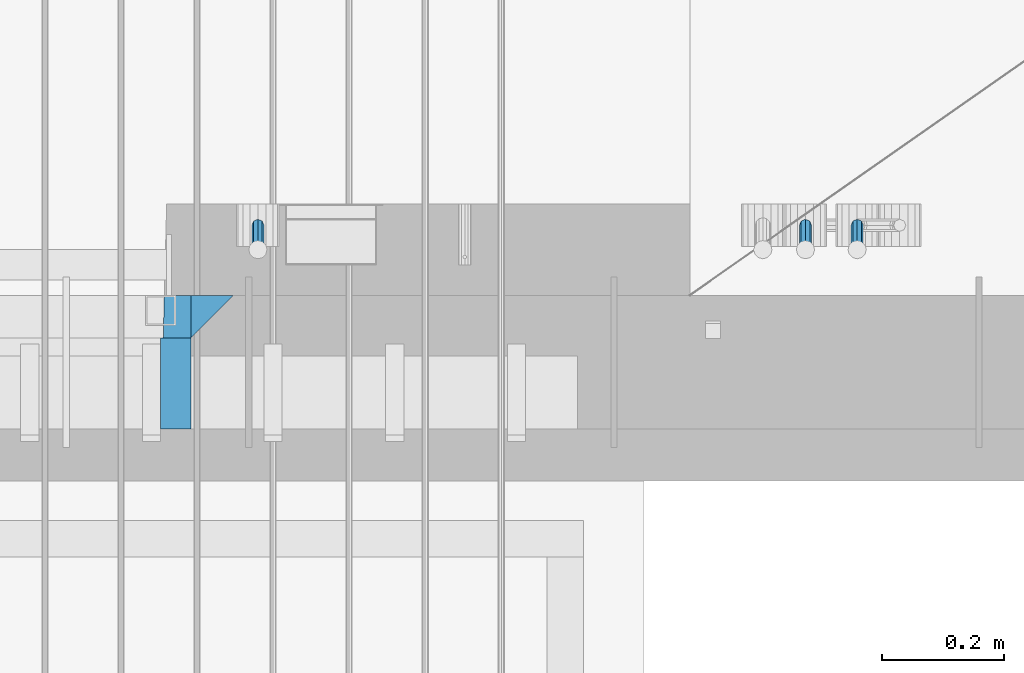
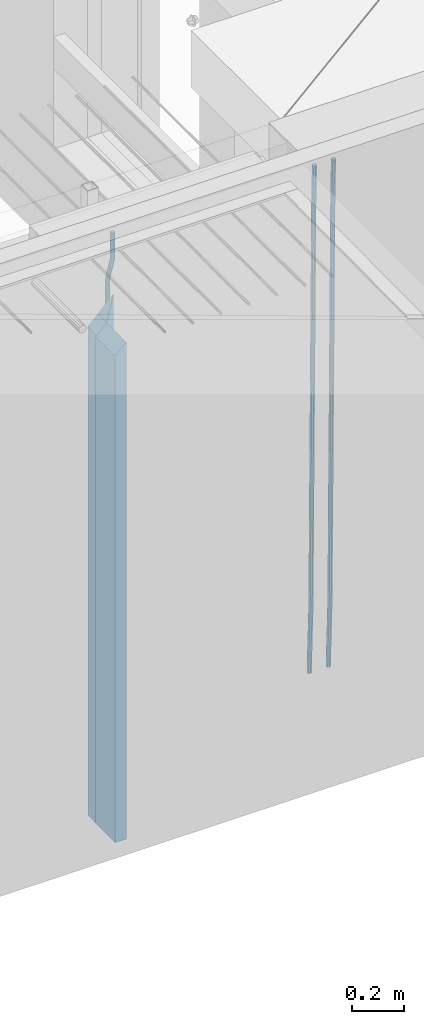
# One storey, part 125 of 341: 6 beams, 1 element without a shape of its own.
"""IFC2X3 building model written with IfcOpenShell, lengths in millimetres."""

from ifc_helpers import new_model, si_unit, frame, origin_with_axes, place, context, subcontext, project, spatial, faceted_brep, material, type_object, element, aggregate, save


model = new_model("IFC2X3")

# Units and contexts
model_context = context("Model", 3, precision=1e-05, world=origin_with_axes())
body_context = subcontext(model_context, "Body", "Model", "MODEL_VIEW")
ifc_project = project(units=[si_unit("LENGTHUNIT", "METRE", prefix="MILLI"), si_unit("AREAUNIT", "SQUARE_METRE"), si_unit("VOLUMEUNIT", "CUBIC_METRE"), si_unit("MASSUNIT", "GRAM", prefix="KILO"), si_unit("TIMEUNIT", "SECOND"), si_unit("PLANEANGLEUNIT", "RADIAN"), si_unit("SOLIDANGLEUNIT", "STERADIAN"), si_unit("THERMODYNAMICTEMPERATUREUNIT", "DEGREE_CELSIUS"), si_unit("LUMINOUSINTENSITYUNIT", "LUMEN")], contexts=[model_context])

# Site, building, storey
site_placement = place(None, origin_with_axes())
site = spatial("IfcSite", under=ifc_project, at=site_placement, CompositionType="ELEMENT")
building_placement = place(site_placement, origin_with_axes())
building = spatial("IfcBuilding", under=site, at=building_placement, CompositionType="ELEMENT")
storey_placement = place(building_placement, origin_with_axes())
storey = spatial("IfcBuildingStorey", under=building, at=storey_placement, Name="5", CompositionType="ELEMENT", Elevation=0.0)

# Assembly, beams
assembly_placement = place(storey_placement, origin_with_axes())
assembly = element("IfcElementAssembly", 1, at=assembly_placement, inside=storey, AssemblyPlace="NOTDEFINED", PredefinedType="REINFORCEMENT_UNIT")
ifc_material_1 = material(Name="CONCRETE/C35/45")
beam_type_1 = type_object("IfcBeamType", PredefinedType="NOTDEFINED")
beam_1_placement = place(assembly_placement, frame((33199.9988923323, 7815.0, 96175.0), z_axis=(-1.0, 3.00000001838171e-08, 0.0), x_axis=(0.0, 0.0, -1.0)))
beam_1 = element("IfcBeam", 2, at=beam_1_placement, type_object=beam_type_1, material=ifc_material_1, Name="SK", context=body_context, shape_type="Brep", body=[
    faceted_brep([(2420.0, -35.0, 35.0), (2420.0, -35.0, -35.0), (2420.0, 35.0, 35.0), (0.0, -35.0, -35.0), (70.0000000000164, 35.0, 35.0), (70.0000000000164, -35.0, 35.0)], [[[0, 1, 2]], [[2, 1, 3, 4]], [[0, 2, 4, 5]], [[1, 0, 5, 3]], [[5, 4, 3]]]),
])
beam_type_2 = type_object("IfcBeamType", PredefinedType="NOTDEFINED")
beam_2_placement = place(assembly_placement, frame((33139.9988923323, 7815.0, 96105.0), z_axis=(-1.0, 3.00000001838171e-08, 0.0), x_axis=(0.0, 0.0, -1.0)))
beam_2 = element("IfcBeam", 3, at=beam_2_placement, type_object=beam_type_2, material=ifc_material_1, Name="SK", context=body_context, shape_type="Brep", body=[
    faceted_brep([(2350.0, -35.0, -25.0), (2350.0, 35.0, -25.0), (2350.0, 35.0, 20.6410256410309), (2350.0, -35.0, 18.8461538461561), (0.0, -35.0, -25.0), (0.0, 35.0, -25.0), (45.6410256410309, 35.0, 20.6410256410254), (43.8461538461561, -35.0, 18.8461538461543)], [[[0, 1, 2, 3]], [[1, 0, 4, 5]], [[2, 1, 5, 6]], [[3, 2, 6, 7]], [[0, 3, 7, 4]], [[6, 5, 4, 7]]]),
])
ifc_material_2 = material(Name="TIMBER")
beam_type_3 = type_object("IfcBeamType", Name="50X150", PredefinedType="NOTDEFINED")
beam_3_placement = place(assembly_placement, frame((33139.9988923323, 7705.0, 96105.0), z_axis=(-1.0, 3.00000001838171e-08, 0.0), x_axis=(0.0, 0.0, -1.0)))
beam_3 = element("IfcBeam", 4, at=beam_3_placement, type_object=beam_type_3, material=ifc_material_2, ObjectType="50X150", context=body_context, shape_type="Brep", body=[
    faceted_brep([(2345.0, -75.0, 25.0), (2345.0, -75.0, -25.0), (2345.0, 75.0, -25.0), (2345.0, 75.0, 25.0), (0.0, -75.0, -25.0), (0.0, 75.0, -25.0), (50.0000000000036, 75.0, 25.0), (50.0000000000036, -75.0, 25.0)], [[[0, 1, 2, 3]], [[4, 5, 2, 1]], [[3, 2, 5, 6]], [[0, 3, 6, 7]], [[1, 0, 7, 4]], [[7, 6, 5, 4]]]),
])
ifc_material_3 = material()
beam_type_4 = type_object("IfcBeamType", Name="D20", PredefinedType="NOTDEFINED")
beam_4_placement = place(assembly_placement, frame((33274.9999999916, 7925.0, 96407.5), z_axis=(0.000415599999849905, 0.999999913638203, 4.76000000899737e-07), x_axis=(0.0, 0.0, -1.0)))
beam_4 = element("IfcBeam", 5, at=beam_4_placement, type_object=beam_type_4, material=ifc_material_3, Name="JM20", ObjectType="D20", context=body_context, shape_type="Brep", body=[
    faceted_brep([(0.0, -10.0, 0.0), (-4.19531716033816e-08, -7.07106781186667, -7.07106781187031), (113.248091332178, -7.0710684840451, -7.0710678117357), (113.248091314759, -10.0000006713562, -2.51020537689328e-10), (0.0, 0.0, -10.0), (113.248091374131, -6.72178430249915e-07, -9.99999999986903), (4.196772351861e-08, 7.07106781186303, -7.07106781186667), (113.248091416113, 7.07106713968824, -7.07106781173934), (0.0, 10.0, 0.0), (113.248091433488, 9.99999932782521, 1.30967237055302e-10), (4.196772351861e-08, 7.07106781185939, 7.07106781185939), (113.248091416113, 7.0710671396846, 7.071067811994), (0.0, 0.0, 10.0), (113.248091374131, -6.72174792271107e-07, 10.0000000001273), (-4.19531716033816e-08, -7.07106781187031, 7.07106781185939), (113.248091332178, -7.0710684840451, 7.071067811994), (130.699843527167, -7.06993249763036, -4.33745683788584), (128.538066582521, -9.99900540317321, 2.39499413731755), (131.594536475241, 0.00119355250353692, -7.12624594330919), (130.698046432328, 7.07220300913468, -4.33773834422391), (128.535525107087, 10.0009944322555, 2.39459602660281), (126.373748162892, 7.07192152754578, 9.1270470011732), (125.479055214906, 0.000795477419160306, 11.9158361066184), (126.37554525779, -7.07021397921199, 9.12732850753673), (240.336258550378, -7.05529970173666, 30.8729495437874), (238.174481606227, -9.98437260450009, 37.6054005176375), (241.230951498423, 0.0158263482953771, 28.0841604381058), (240.334461455612, 7.0868358050102, 30.8726680369582), (238.171940130502, 10.0156272283348, 37.6050024077231), (236.010163186409, 7.08655432384694, 44.3374533824244), (235.115470238379, 0.0154282738185429, 47.1262424881097), (236.011960281176, -7.05558118289991, 44.3377348892536), (253.461915329972, -7.05444528127919, 32.9289287376414), (253.46191532613, -9.98337746617108, 39.9999965521893), (253.461915339081, 0.0166225284556276, 29.9999965443676), (253.461915348205, 7.08769034247234, 32.9289287273205), (253.461915352003, 10.0166225357716, 39.9999965370152), (253.461915348293, 7.08769035281148, 47.0710643509774), (253.461915339183, 0.0166225430875784, 49.999996544273), (253.46191533003, -7.05444527093641, 47.0710643613093), (2417.50000002384, -7.0544364694706, 32.9289287374122), (2417.5000000337, -9.98336865393321, 39.9999965507959), (2417.49999999997, 0.0166313408753922, 29.9999965456082), (2417.49999997609, 7.08769915426274, 32.9289287300708), (2417.4999999662, 10.0166313460668, 39.9999965404204), (2417.49999997608, 7.08769916160054, 47.0710643538114), (2417.49999999994, 0.0166313512581837, 49.9999965456154), (2417.50000002382, -7.05443646212916, 47.0710643611455)], [[[0, 1, 2, 3]], [[1, 4, 5, 2]], [[4, 6, 7, 5]], [[6, 8, 9, 7]], [[8, 10, 11, 9]], [[10, 12, 13, 11]], [[12, 14, 15, 13]], [[14, 0, 3, 15]], [[14, 12, 10, 8, 6, 4, 1, 0]], [[3, 2, 16, 17]], [[2, 5, 18, 16]], [[5, 7, 19, 18]], [[7, 9, 20, 19]], [[9, 11, 21, 20]], [[11, 13, 22, 21]], [[13, 15, 23, 22]], [[15, 3, 17, 23]], [[17, 16, 24, 25]], [[16, 18, 26, 24]], [[18, 19, 27, 26]], [[19, 20, 28, 27]], [[20, 21, 29, 28]], [[21, 22, 30, 29]], [[22, 23, 31, 30]], [[23, 17, 25, 31]], [[25, 24, 32, 33]], [[24, 26, 34, 32]], [[26, 27, 35, 34]], [[27, 28, 36, 35]], [[28, 29, 37, 36]], [[29, 30, 38, 37]], [[30, 31, 39, 38]], [[31, 25, 33, 39]], [[33, 32, 40, 41]], [[32, 34, 42, 40]], [[34, 35, 43, 42]], [[35, 36, 44, 43]], [[36, 37, 45, 44]], [[37, 38, 46, 45]], [[38, 39, 47, 46]], [[39, 33, 41, 47]], [[42, 43, 44, 45, 46, 47, 41, 40]]]),
])
beam_5_placement = place(assembly_placement, frame((34259.9999999961, 7965.00000227913, 93990.0), z_axis=(0.00020576299992186, -0.999642804629538, -0.0267249099901004), x_axis=(-4.30000201928125e-08, -0.0267249099948059, 0.999642825806181)))
beam_5 = element("IfcBeam", 6, at=beam_5_placement, type_object=beam_type_4, material=ifc_material_3, Name="JM20", ObjectType="D20", context=body_context, shape_type="Brep", body=[
    faceted_brep([(0.0, -10.0, 0.0), (-4.19531716033816e-08, -7.07106781186667, -7.07106781187031), (60.4266690400545, -7.0710677960451, -7.07106780570757), (60.4266690441291, -9.99999998418934, 6.15546014159918e-09), (0.0, 0.0, -10.0), (60.426669036824, 1.58106558956206e-08, -9.99999999384454), (4.196772351861e-08, 7.07106781186303, -7.07106781186667), (60.4266690363438, 7.07106782768096, -7.07106780570757), (0.0, 10.0, 0.0), (60.4266690388904, 10.0000000158179, 6.15182216279209e-09), (4.196772351861e-08, 7.07106781185939, 7.07106781185939), (60.4266690429649, 7.07106782768096, 7.07106781802577), (0.0, 0.0, 10.0), (60.4266690461809, 1.58179318532348e-08, 10.0000000061555), (-4.19531716033816e-08, -7.07106781187031, 7.07106781185939), (60.4266690466611, -7.07106779605238, 7.07106781802213), (61.0378400410118, -7.07106779588503, -7.07106780564936), (60.991799419251, -9.99999998403655, 6.21366780251265e-09), (61.0569027789461, 1.5985278878361e-08, -9.99999999378269), (61.0378209396877, 7.07106782784831, -7.07106780564936), (60.9917724058905, 10.0000000159635, 6.21366780251265e-09), (60.9457317841297, 7.07106782781193, 7.0710678180767), (60.9266690461809, 1.59488990902901e-08, 10.0000000062028), (60.9457508854539, -7.07106779591413, 7.0710678180767), (61.6489592143771, -7.07106614513759, -7.06310863441468), (61.5568818710308, -9.9999984576425, 0.00735959856683621), (61.6870830769039, 1.71821739058942e-06, -9.99179257185824), (61.6489210170112, 7.07106947854481, -7.06310888312146), (61.556827851804, 10.0000015422847, 0.00735924683976918), (61.4647505084577, 7.07106922979438, 7.07782747982128), (61.4266266459163, 1.36643211590126e-06, 10.0065114172685), (61.464788705809, -7.07106639389531, 7.07782772852806), (176.543135720174, -7.07075579406956, -5.56673531796696), (176.451058376813, -9.99968810657447, 1.50373291501455), (176.581259582701, 0.000312069292704109, -8.49541925541052), (176.543097522794, 7.07137982961285, -5.56673556667374), (176.451004357587, 10.00031189336, 1.50373256329476), (176.35892701424, 7.07137958085514, 8.57420079627263), (176.320803151699, 0.000311717507429421, 11.5028847337162), (176.358965211621, -7.07075604281999, 8.57420104497578), (177.098753836006, -7.07075429323595, -5.55949898843028), (176.98362511232, -9.99968666800123, 1.510669025065), (177.146421932586, 0.000313595905026887, -8.48805862247536), (177.098706077581, 7.07138133041735, -5.55949936166144), (176.983557571715, 10.0003133318824, 1.51066849724157), (176.868428848029, 7.07138095712435, 8.58083651073321), (176.820760751449, 0.000313067976094317, 11.5093961447819), (176.868476606425, -7.07075466652896, 8.58083688396073), (177.654312950661, -7.07075204110879, -5.54863964998367), (177.516135294456, -9.99968450931192, 1.52107783331303), (177.711524267797, 0.000315886711177882, -8.47701274570863), (177.654255632195, 7.07138358250813, -5.54864021007961), (177.516054233929, 10.0003154905207, 1.5210770412159), (177.377876577739, 7.0713830223176, 8.59079452451624), (177.320665260588, 0.000315094497636892, 11.5191676202448), (177.377933896176, -7.07075260129932, 8.59079508461218), (299.436796249574, -7.07025836271714, -3.1681962331204), (299.298618593355, -9.99919083092027, 3.90152125031091), (299.494007566798, 0.000809565110102994, -6.09656932889993), (299.436738931283, 7.07187726089978, -3.16819679320906), (299.298537533061, 10.0008091689197, 3.90152045822106), (299.160359876842, 7.07187670072017, 10.9712379416487), (299.103148559603, 0.000808772889286047, 13.8996110374392), (299.160417195119, -7.07025892290039, 10.9712385017483), (299.98743051647, -7.07025613056248, -3.15743315966392), (299.971788958996, -9.99918809853989, 3.91467979818117), (299.993912075952, 0.000811591617093654, -6.08679785393178), (299.987423933868, 7.07187949325817, -3.1574327280432), (299.971753863239, 10.0008119014747, 3.91467990454839), (299.95611230444, 7.07187992653053, 10.9867922621015), (299.949630744944, 0.000812204350950196, 13.9161569563694), (299.956118887014, -7.07025569729012, 10.9867918304735), (300.538107039494, -7.07025785017686, -3.16575821840888), (300.644985195438, -9.99919020432935, 3.90450175465594), (300.493854948218, 0.000810030429420294, -6.09435592770024), (300.538151196495, 7.071877773491, -3.16575855385963), (300.645047642858, 10.0008097955724, 3.90450128024895), (300.751925798773, 7.07187744142357, 10.9747612533101), (300.796177890064, 0.000809560813650023, 13.9033589625978), (300.751881641787, -7.07025818224065, 10.9747615887682), (2293.36490490142, -7.07648090940347, -33.2930642912361), (2293.47178305736, -10.0054132635523, -26.2228043181785), (2293.32065281013, -0.00541302880083094, -36.2216620005347), (2293.36494905842, 7.06565471425711, -33.2930646266868), (2293.47184550477, 9.99458673634581, -26.2228047925819), (2293.57872366071, 7.06565438219332, -19.1525448195243), (2293.62297575199, -0.00541349841296324, -16.2239471102366), (2293.57867950371, -7.0764812414709, -19.1525444840736), (2294.0658245362, -7.07648309818615, -33.3036607065333), (2294.05312277409, -10.0054150789219, -26.2315929392535), (2294.10928714235, -0.00541549149056664, -36.2335844756526), (2294.15805078732, 7.06565223761572, -33.3050546393533), (2294.18355038921, 9.99458451388637, -26.2335642579346), (2294.17084862708, 7.06565253314329, -19.1614964906439), (2294.12738602093, -0.00541507354500936, -16.2315727215355), (2294.07862237596, -7.07648280265857, -19.1601025578348), (2294.76670261032, -7.08562269121467, -33.294332712383), (2294.63442802057, -10.0129954178956, -26.2238563411993), (2294.89787471293, -0.0156988342423574, -36.2230891548279), (2294.95110548967, 7.05531064255774, -33.2944998654275), (2294.89521307347, 9.98530428734011, -26.2240927312887), (2294.76293848372, 7.0579315606592, -19.1536163601049), (2294.63176638114, -0.0119922963167483, -16.2248599176673), (2294.57853560438, -7.08300177311321, -19.1534492070678), (2316.52657204497, -7.36937582653991, -33.0047303660212), (2316.39429745522, -10.2967485532172, -25.9342539948302), (2316.65774414754, -0.299451969567599, -35.9334868084661), (2316.7109749243, 6.7715575072325, -33.0048975190657), (2316.65508250811, 9.70155115201487, -25.9344903849269), (2316.52280791836, 6.7741784253376, -18.8640140137468), (2316.39163581574, -0.295745431634714, -15.9352575713092), (2316.33840503903, -7.36675490843481, -18.863846860706), (2317.16202064224, -7.37766220584308, -32.9962731735213), (2317.05438744847, -10.3053562613532, -25.9254688497131), (2317.23607125619, -0.306993473008333, -35.925789846493), (2317.23316144495, 6.76474808850253, -32.9979477328052), (2317.15499573652, 9.6950321815566, -25.9278370341635), (2317.04736254275, 6.7673381260538, -18.8570327103698), (2316.97331192881, -0.303330606784584, -15.9275160373909), (2316.97622174003, -7.37507216829545, -18.8553581510787), (2317.79752306276, -7.37578610372293, -32.9880110666527), (2317.71453320107, -10.3033876998124, -25.9168792378296), (2317.81444760226, -0.305295583297266, -35.918287695793), (2317.75539265381, 6.76628640723357, -32.9911928173897), (2317.65495180529, 9.69652304524061, -25.9213789128698), (2317.5719619436, 6.76892144914746, -18.8502470840467), (2317.55503740412, -0.301569071270933, -15.9199704549137), (2317.61409235255, -7.3731510618054, -18.847065333317), (2417.8183084176, -7.07752398473531, -31.6906369377139), (2417.73531855589, -10.0051255808248, -24.6195051088798), (2417.83523295709, -0.007033464313281, -34.6209135668432), (2417.77617800863, 7.06454852621755, -31.6938186884508), (2417.67573716014, 9.99478516423187, -24.6240047839383), (2417.59274729842, 7.06718356813872, -17.5528729551006), (2417.57582275895, -0.00330695228694822, -14.6225963259749), (2417.6348777074, -7.07488894281778, -17.5496912043673)], [[[0, 1, 2, 3]], [[1, 4, 5, 2]], [[4, 6, 7, 5]], [[6, 8, 9, 7]], [[8, 10, 11, 9]], [[10, 12, 13, 11]], [[12, 14, 15, 13]], [[14, 0, 3, 15]], [[14, 12, 10, 8, 6, 4, 1, 0]], [[3, 2, 16, 17]], [[2, 5, 18, 16]], [[5, 7, 19, 18]], [[7, 9, 20, 19]], [[9, 11, 21, 20]], [[11, 13, 22, 21]], [[13, 15, 23, 22]], [[15, 3, 17, 23]], [[17, 16, 24, 25]], [[16, 18, 26, 24]], [[18, 19, 27, 26]], [[19, 20, 28, 27]], [[20, 21, 29, 28]], [[21, 22, 30, 29]], [[22, 23, 31, 30]], [[23, 17, 25, 31]], [[25, 24, 32, 33]], [[24, 26, 34, 32]], [[26, 27, 35, 34]], [[27, 28, 36, 35]], [[28, 29, 37, 36]], [[29, 30, 38, 37]], [[30, 31, 39, 38]], [[31, 25, 33, 39]], [[33, 32, 40, 41]], [[32, 34, 42, 40]], [[34, 35, 43, 42]], [[35, 36, 44, 43]], [[36, 37, 45, 44]], [[37, 38, 46, 45]], [[38, 39, 47, 46]], [[39, 33, 41, 47]], [[41, 40, 48, 49]], [[40, 42, 50, 48]], [[42, 43, 51, 50]], [[43, 44, 52, 51]], [[44, 45, 53, 52]], [[45, 46, 54, 53]], [[46, 47, 55, 54]], [[47, 41, 49, 55]], [[49, 48, 56, 57]], [[48, 50, 58, 56]], [[50, 51, 59, 58]], [[51, 52, 60, 59]], [[52, 53, 61, 60]], [[53, 54, 62, 61]], [[54, 55, 63, 62]], [[55, 49, 57, 63]], [[57, 56, 64, 65]], [[56, 58, 66, 64]], [[58, 59, 67, 66]], [[59, 60, 68, 67]], [[60, 61, 69, 68]], [[61, 62, 70, 69]], [[62, 63, 71, 70]], [[63, 57, 65, 71]], [[65, 64, 72, 73]], [[64, 66, 74, 72]], [[66, 67, 75, 74]], [[67, 68, 76, 75]], [[68, 69, 77, 76]], [[69, 70, 78, 77]], [[70, 71, 79, 78]], [[71, 65, 73, 79]], [[73, 72, 80, 81]], [[72, 74, 82, 80]], [[74, 75, 83, 82]], [[75, 76, 84, 83]], [[76, 77, 85, 84]], [[77, 78, 86, 85]], [[78, 79, 87, 86]], [[79, 73, 81, 87]], [[81, 80, 88, 89]], [[80, 82, 90, 88]], [[82, 83, 91, 90]], [[83, 84, 92, 91]], [[84, 85, 93, 92]], [[85, 86, 94, 93]], [[86, 87, 95, 94]], [[87, 81, 89, 95]], [[89, 88, 96, 97]], [[88, 90, 98, 96]], [[90, 91, 99, 98]], [[91, 92, 100, 99]], [[92, 93, 101, 100]], [[93, 94, 102, 101]], [[94, 95, 103, 102]], [[95, 89, 97, 103]], [[97, 96, 104, 105]], [[96, 98, 106, 104]], [[98, 99, 107, 106]], [[99, 100, 108, 107]], [[100, 101, 109, 108]], [[101, 102, 110, 109]], [[102, 103, 111, 110]], [[103, 97, 105, 111]], [[105, 104, 112, 113]], [[104, 106, 114, 112]], [[106, 107, 115, 114]], [[107, 108, 116, 115]], [[108, 109, 117, 116]], [[109, 110, 118, 117]], [[110, 111, 119, 118]], [[111, 105, 113, 119]], [[113, 112, 120, 121]], [[112, 114, 122, 120]], [[114, 115, 123, 122]], [[115, 116, 124, 123]], [[116, 117, 125, 124]], [[117, 118, 126, 125]], [[118, 119, 127, 126]], [[119, 113, 121, 127]], [[121, 120, 128, 129]], [[120, 122, 130, 128]], [[122, 123, 131, 130]], [[123, 124, 132, 131]], [[124, 125, 133, 132]], [[125, 126, 134, 133]], [[126, 127, 135, 134]], [[127, 121, 129, 135]], [[130, 131, 132, 133, 134, 135, 129, 128]]]),
])
beam_6_placement = place(assembly_placement, frame((34174.9999999961, 7965.00000227913, 93990.0), z_axis=(0.00020576299992186, -0.999642804629538, -0.0267249099901004), x_axis=(-4.30000201928125e-08, -0.0267249099948059, 0.999642825806181)))
beam_6 = element("IfcBeam", 7, at=beam_6_placement, type_object=beam_type_4, material=ifc_material_3, Name="JM20", ObjectType="D20", context=body_context, shape_type="Brep", body=[
    faceted_brep([(0.0, -10.0, 0.0), (-4.19531716033816e-08, -7.07106781186667, -7.07106781187031), (60.4266690400545, -7.0710677960451, -7.07106780570757), (60.4266690441291, -9.99999998418934, 6.15546014159918e-09), (0.0, 0.0, -10.0), (60.426669036824, 1.58106558956206e-08, -9.99999999384454), (4.196772351861e-08, 7.07106781186303, -7.07106781186667), (60.4266690363438, 7.07106782768096, -7.07106780570757), (0.0, 10.0, 0.0), (60.4266690388904, 10.0000000158179, 6.15182216279209e-09), (4.196772351861e-08, 7.07106781185939, 7.07106781185939), (60.4266690429649, 7.07106782768096, 7.07106781802577), (0.0, 0.0, 10.0), (60.4266690461809, 1.58179318532348e-08, 10.0000000061555), (-4.19531716033816e-08, -7.07106781187031, 7.07106781185939), (60.4266690466611, -7.07106779605238, 7.07106781802213), (61.0378400410118, -7.07106779588503, -7.07106780564936), (60.991799419251, -9.99999998403655, 6.21366780251265e-09), (61.0569027789461, 1.5985278878361e-08, -9.99999999378269), (61.0378209396877, 7.07106782784831, -7.07106780564936), (60.9917724058905, 10.0000000159635, 6.21366780251265e-09), (60.9457317841297, 7.07106782781193, 7.0710678180767), (60.9266690461809, 1.59488990902901e-08, 10.0000000062028), (60.9457508854539, -7.07106779591413, 7.0710678180767), (61.6489592143771, -7.07106614513759, -7.06310863441468), (61.5568818710308, -9.9999984576425, 0.00735959856683621), (61.6870830769039, 1.71821739058942e-06, -9.99179257185824), (61.6489210170112, 7.07106947854481, -7.06310888312146), (61.556827851804, 10.0000015422847, 0.00735924683976918), (61.4647505084577, 7.07106922979438, 7.07782747982128), (61.4266266459163, 1.36643211590126e-06, 10.0065114172685), (61.464788705809, -7.07106639389531, 7.07782772852806), (176.543135720174, -7.07075579406956, -5.56673531796696), (176.451058376813, -9.99968810657447, 1.50373291501455), (176.581259582701, 0.000312069292704109, -8.49541925541052), (176.543097522794, 7.07137982961285, -5.56673556667374), (176.451004357587, 10.00031189336, 1.50373256329476), (176.35892701424, 7.07137958085514, 8.57420079627263), (176.320803151699, 0.000311717507429421, 11.5028847337162), (176.358965211621, -7.07075604281999, 8.57420104497578), (177.098753836006, -7.07075429323595, -5.55949898843028), (176.98362511232, -9.99968666800123, 1.510669025065), (177.146421932586, 0.000313595905026887, -8.48805862247536), (177.098706077581, 7.07138133041735, -5.55949936166144), (176.983557571715, 10.0003133318824, 1.51066849724157), (176.868428848029, 7.07138095712435, 8.58083651073321), (176.820760751449, 0.000313067976094317, 11.5093961447819), (176.868476606425, -7.07075466652896, 8.58083688396073), (177.654312950661, -7.07075204110879, -5.54863964998367), (177.516135294456, -9.99968450931192, 1.52107783331303), (177.711524267797, 0.000315886711177882, -8.47701274570863), (177.654255632195, 7.07138358250813, -5.54864021007961), (177.516054233929, 10.0003154905207, 1.5210770412159), (177.377876577739, 7.0713830223176, 8.59079452451624), (177.320665260588, 0.000315094497636892, 11.5191676202448), (177.377933896176, -7.07075260129932, 8.59079508461218), (299.436796249574, -7.07025836271714, -3.1681962331204), (299.298618593355, -9.99919083092027, 3.90152125031091), (299.494007566798, 0.000809565110102994, -6.09656932889993), (299.436738931283, 7.07187726089978, -3.16819679320906), (299.298537533061, 10.0008091689197, 3.90152045822106), (299.160359876842, 7.07187670072017, 10.9712379416487), (299.103148559603, 0.000808772889286047, 13.8996110374392), (299.160417195119, -7.07025892290039, 10.9712385017483), (299.98743051647, -7.07025613056248, -3.15743315966392), (299.971788958996, -9.99918809853989, 3.91467979818117), (299.993912075952, 0.000811591617093654, -6.08679785393178), (299.987423933868, 7.07187949325817, -3.1574327280432), (299.971753863239, 10.0008119014747, 3.91467990454839), (299.95611230444, 7.07187992653053, 10.9867922621015), (299.949630744944, 0.000812204350950196, 13.9161569563694), (299.956118887014, -7.07025569729012, 10.9867918304735), (300.538107039494, -7.07025785017686, -3.16575821840888), (300.644985195438, -9.99919020432935, 3.90450175465594), (300.493854948218, 0.000810030429420294, -6.09435592770024), (300.538151196495, 7.071877773491, -3.16575855385963), (300.645047642858, 10.0008097955724, 3.90450128024895), (300.751925798773, 7.07187744142357, 10.9747612533101), (300.796177890064, 0.000809560813650023, 13.9033589625978), (300.751881641787, -7.07025818224065, 10.9747615887682), (2293.36490490142, -7.07648090940347, -33.2930642912361), (2293.47178305736, -10.0054132635523, -26.2228043181785), (2293.32065281013, -0.00541302880083094, -36.2216620005347), (2293.36494905842, 7.06565471425711, -33.2930646266868), (2293.47184550477, 9.99458673634581, -26.2228047925819), (2293.57872366071, 7.06565438219332, -19.1525448195243), (2293.62297575199, -0.00541349841296324, -16.2239471102366), (2293.57867950371, -7.0764812414709, -19.1525444840736), (2294.0658245362, -7.07648309818615, -33.3036607065333), (2294.05312277409, -10.0054150789219, -26.2315929392535), (2294.10928714235, -0.00541549149056664, -36.2335844756526), (2294.15805078732, 7.06565223761572, -33.3050546393533), (2294.18355038921, 9.99458451388637, -26.2335642579346), (2294.17084862708, 7.06565253314329, -19.1614964906439), (2294.12738602093, -0.00541507354500936, -16.2315727215355), (2294.07862237596, -7.07648280265857, -19.1601025578348), (2294.76670261032, -7.08562269121467, -33.294332712383), (2294.63442802057, -10.0129954178956, -26.2238563411993), (2294.89787471293, -0.0156988342423574, -36.2230891548279), (2294.95110548967, 7.05531064255774, -33.2944998654275), (2294.89521307347, 9.98530428734011, -26.2240927312887), (2294.76293848372, 7.0579315606592, -19.1536163601049), (2294.63176638114, -0.0119922963167483, -16.2248599176673), (2294.57853560438, -7.08300177311321, -19.1534492070678), (2316.52657204497, -7.36937582653991, -33.0047303660212), (2316.39429745522, -10.2967485532172, -25.9342539948302), (2316.65774414754, -0.299451969567599, -35.9334868084661), (2316.7109749243, 6.7715575072325, -33.0048975190657), (2316.65508250811, 9.70155115201487, -25.9344903849269), (2316.52280791836, 6.7741784253376, -18.8640140137468), (2316.39163581574, -0.295745431634714, -15.9352575713092), (2316.33840503903, -7.36675490843481, -18.863846860706), (2317.16202064224, -7.37766220584308, -32.9962731735213), (2317.05438744847, -10.3053562613532, -25.9254688497131), (2317.23607125619, -0.306993473008333, -35.925789846493), (2317.23316144495, 6.76474808850253, -32.9979477328052), (2317.15499573652, 9.6950321815566, -25.9278370341635), (2317.04736254275, 6.7673381260538, -18.8570327103698), (2316.97331192881, -0.303330606784584, -15.9275160373909), (2316.97622174003, -7.37507216829545, -18.8553581510787), (2317.79752306276, -7.37578610372293, -32.9880110666527), (2317.71453320107, -10.3033876998124, -25.9168792378296), (2317.81444760226, -0.305295583297266, -35.918287695793), (2317.75539265381, 6.76628640723357, -32.9911928173897), (2317.65495180529, 9.69652304524061, -25.9213789128698), (2317.5719619436, 6.76892144914746, -18.8502470840467), (2317.55503740412, -0.301569071270933, -15.9199704549137), (2317.61409235255, -7.3731510618054, -18.847065333317), (2417.8183084176, -7.07752398473531, -31.6906369377139), (2417.73531855589, -10.0051255808248, -24.6195051088798), (2417.83523295709, -0.007033464313281, -34.6209135668432), (2417.77617800863, 7.06454852621755, -31.6938186884508), (2417.67573716014, 9.99478516423187, -24.6240047839383), (2417.59274729842, 7.06718356813872, -17.5528729551006), (2417.57582275895, -0.00330695228694822, -14.6225963259749), (2417.6348777074, -7.07488894281778, -17.5496912043673)], [[[0, 1, 2, 3]], [[1, 4, 5, 2]], [[4, 6, 7, 5]], [[6, 8, 9, 7]], [[8, 10, 11, 9]], [[10, 12, 13, 11]], [[12, 14, 15, 13]], [[14, 0, 3, 15]], [[14, 12, 10, 8, 6, 4, 1, 0]], [[3, 2, 16, 17]], [[2, 5, 18, 16]], [[5, 7, 19, 18]], [[7, 9, 20, 19]], [[9, 11, 21, 20]], [[11, 13, 22, 21]], [[13, 15, 23, 22]], [[15, 3, 17, 23]], [[17, 16, 24, 25]], [[16, 18, 26, 24]], [[18, 19, 27, 26]], [[19, 20, 28, 27]], [[20, 21, 29, 28]], [[21, 22, 30, 29]], [[22, 23, 31, 30]], [[23, 17, 25, 31]], [[25, 24, 32, 33]], [[24, 26, 34, 32]], [[26, 27, 35, 34]], [[27, 28, 36, 35]], [[28, 29, 37, 36]], [[29, 30, 38, 37]], [[30, 31, 39, 38]], [[31, 25, 33, 39]], [[33, 32, 40, 41]], [[32, 34, 42, 40]], [[34, 35, 43, 42]], [[35, 36, 44, 43]], [[36, 37, 45, 44]], [[37, 38, 46, 45]], [[38, 39, 47, 46]], [[39, 33, 41, 47]], [[41, 40, 48, 49]], [[40, 42, 50, 48]], [[42, 43, 51, 50]], [[43, 44, 52, 51]], [[44, 45, 53, 52]], [[45, 46, 54, 53]], [[46, 47, 55, 54]], [[47, 41, 49, 55]], [[49, 48, 56, 57]], [[48, 50, 58, 56]], [[50, 51, 59, 58]], [[51, 52, 60, 59]], [[52, 53, 61, 60]], [[53, 54, 62, 61]], [[54, 55, 63, 62]], [[55, 49, 57, 63]], [[57, 56, 64, 65]], [[56, 58, 66, 64]], [[58, 59, 67, 66]], [[59, 60, 68, 67]], [[60, 61, 69, 68]], [[61, 62, 70, 69]], [[62, 63, 71, 70]], [[63, 57, 65, 71]], [[65, 64, 72, 73]], [[64, 66, 74, 72]], [[66, 67, 75, 74]], [[67, 68, 76, 75]], [[68, 69, 77, 76]], [[69, 70, 78, 77]], [[70, 71, 79, 78]], [[71, 65, 73, 79]], [[73, 72, 80, 81]], [[72, 74, 82, 80]], [[74, 75, 83, 82]], [[75, 76, 84, 83]], [[76, 77, 85, 84]], [[77, 78, 86, 85]], [[78, 79, 87, 86]], [[79, 73, 81, 87]], [[81, 80, 88, 89]], [[80, 82, 90, 88]], [[82, 83, 91, 90]], [[83, 84, 92, 91]], [[84, 85, 93, 92]], [[85, 86, 94, 93]], [[86, 87, 95, 94]], [[87, 81, 89, 95]], [[89, 88, 96, 97]], [[88, 90, 98, 96]], [[90, 91, 99, 98]], [[91, 92, 100, 99]], [[92, 93, 101, 100]], [[93, 94, 102, 101]], [[94, 95, 103, 102]], [[95, 89, 97, 103]], [[97, 96, 104, 105]], [[96, 98, 106, 104]], [[98, 99, 107, 106]], [[99, 100, 108, 107]], [[100, 101, 109, 108]], [[101, 102, 110, 109]], [[102, 103, 111, 110]], [[103, 97, 105, 111]], [[105, 104, 112, 113]], [[104, 106, 114, 112]], [[106, 107, 115, 114]], [[107, 108, 116, 115]], [[108, 109, 117, 116]], [[109, 110, 118, 117]], [[110, 111, 119, 118]], [[111, 105, 113, 119]], [[113, 112, 120, 121]], [[112, 114, 122, 120]], [[114, 115, 123, 122]], [[115, 116, 124, 123]], [[116, 117, 125, 124]], [[117, 118, 126, 125]], [[118, 119, 127, 126]], [[119, 113, 121, 127]], [[121, 120, 128, 129]], [[120, 122, 130, 128]], [[122, 123, 131, 130]], [[123, 124, 132, 131]], [[124, 125, 133, 132]], [[125, 126, 134, 133]], [[126, 127, 135, 134]], [[127, 121, 129, 135]], [[130, 131, 132, 133, 134, 135, 129, 128]]]),
])
aggregate(assembly, [beam_4, beam_5, beam_6, beam_1, beam_2, beam_3])

save(model, "model.ifc")
